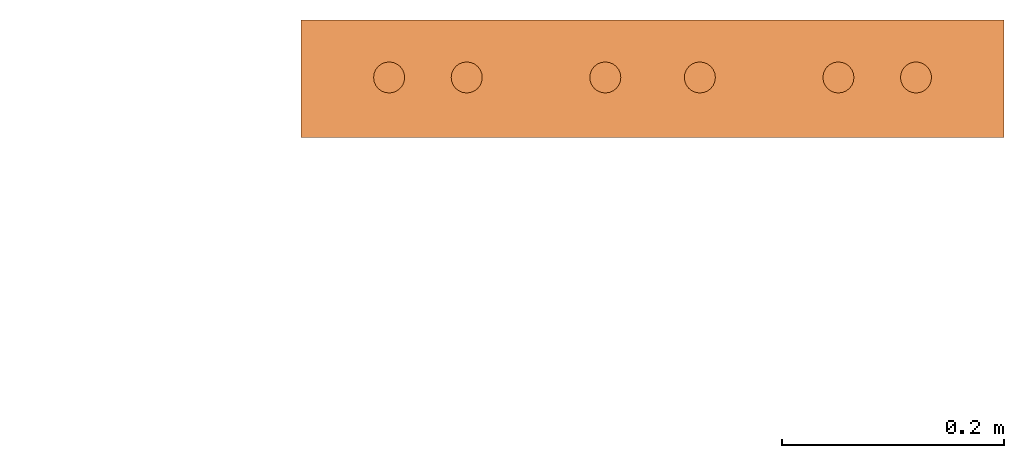
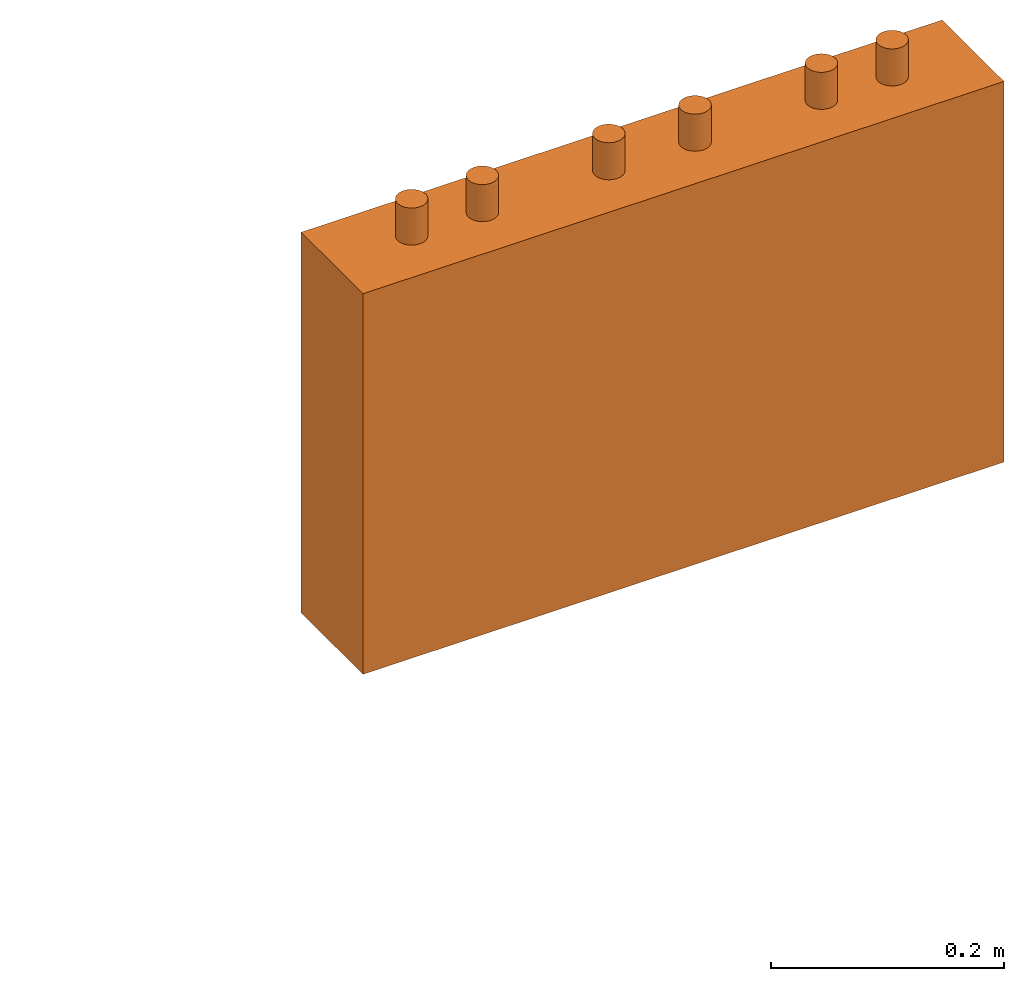
# One storey, part 4 of 5: 1 proxy.
"""IFC2X3 building model written with IfcOpenShell, lengths in millimetres."""

from ifc_helpers import new_model, entity, si_unit, converted_unit, derived_unit, direction, frame, origin, place, context, subcontext, project, spatial, faceted_brep, source, transform, mapped, material, material_list, type_object, type_shapes, element, save


model = new_model("IFC2X3")

# Units and contexts
model_context = context("Model", 3, precision=0.01, world=origin(), true_north=direction((6.12303176911189e-17, 1.0)))
body_context = subcontext(model_context, "Body", "Model", "MODEL_VIEW")
ifc_project = project(units=[si_unit("LENGTHUNIT", "METRE", prefix="MILLI"), si_unit("AREAUNIT", "SQUARE_METRE"), si_unit("VOLUMEUNIT", "CUBIC_METRE"), converted_unit("PLANEANGLEUNIT", "DEGREE", entity("IfcRatioMeasure", 0.0174532925199433), si_unit("PLANEANGLEUNIT", "RADIAN"), dimensions=[0, 0, 0, 0, 0, 0, 0]), si_unit("MASSUNIT", "GRAM", prefix="KILO"), derived_unit("MASSDENSITYUNIT", [(si_unit("MASSUNIT", "GRAM", prefix="KILO"), 1), (si_unit("LENGTHUNIT", "METRE"), -3)]), derived_unit("MOMENTOFINERTIAUNIT", [(si_unit("LENGTHUNIT", "METRE"), 4)]), si_unit("TIMEUNIT", "SECOND"), si_unit("FREQUENCYUNIT", "HERTZ"), si_unit("THERMODYNAMICTEMPERATUREUNIT", "DEGREE_CELSIUS"), derived_unit("THERMALTRANSMITTANCEUNIT", [(si_unit("MASSUNIT", "GRAM", prefix="KILO"), 1), (si_unit("THERMODYNAMICTEMPERATUREUNIT", "KELVIN"), -1), (si_unit("TIMEUNIT", "SECOND"), -3)]), derived_unit("VOLUMETRICFLOWRATEUNIT", [(si_unit("LENGTHUNIT", "METRE"), 3), (si_unit("TIMEUNIT", "SECOND"), -1)]), derived_unit("MASSFLOWRATEUNIT", [(si_unit("MASSUNIT", "GRAM", prefix="KILO"), 1), (si_unit("TIMEUNIT", "SECOND"), -1)]), derived_unit("ROTATIONALFREQUENCYUNIT", [(si_unit("TIMEUNIT", "SECOND"), -1)]), si_unit("ELECTRICCURRENTUNIT", "AMPERE"), si_unit("ELECTRICVOLTAGEUNIT", "VOLT"), si_unit("POWERUNIT", "WATT"), si_unit("FORCEUNIT", "NEWTON", prefix="KILO"), si_unit("ILLUMINANCEUNIT", "LUX"), si_unit("LUMINOUSFLUXUNIT", "LUMEN"), si_unit("LUMINOUSINTENSITYUNIT", "CANDELA"), derived_unit("USERDEFINED", [(si_unit("MASSUNIT", "GRAM", prefix="KILO"), -1), (si_unit("LENGTHUNIT", "METRE"), -2), (si_unit("TIMEUNIT", "SECOND"), 3), (si_unit("LUMINOUSFLUXUNIT", "LUMEN"), 1)]), derived_unit("LINEARVELOCITYUNIT", [(si_unit("LENGTHUNIT", "METRE"), 1), (si_unit("TIMEUNIT", "SECOND"), -1)]), si_unit("PRESSUREUNIT", "PASCAL"), derived_unit("USERDEFINED", [(si_unit("LENGTHUNIT", "METRE"), -2), (si_unit("MASSUNIT", "GRAM", prefix="KILO"), 1), (si_unit("TIMEUNIT", "SECOND"), -2)]), derived_unit("LINEARFORCEUNIT", [(si_unit("MASSUNIT", "GRAM", prefix="KILO"), 1), (si_unit("LENGTHUNIT", "METRE"), 1), (si_unit("TIMEUNIT", "SECOND"), -2), (si_unit("LENGTHUNIT", "METRE"), -1)]), derived_unit("PLANARFORCEUNIT", [(si_unit("MASSUNIT", "GRAM", prefix="KILO"), 1), (si_unit("LENGTHUNIT", "METRE"), 1), (si_unit("TIMEUNIT", "SECOND"), -2), (si_unit("LENGTHUNIT", "METRE"), -2)])], contexts=[model_context])

# Site, building, storey
site_placement = place(None, frame((0.0, 2493.83037508239, 0.0)))
site = spatial("IfcSite", under=ifc_project, at=site_placement, CompositionType="ELEMENT")
building_placement = place(site_placement, origin())
building = spatial("IfcBuilding", under=site, at=building_placement, CompositionType="ELEMENT")
storey_placement = place(building_placement, frame((0.0, 0.0, 19800.0)))
storey = spatial("IfcBuildingStorey", under=building, at=storey_placement, Name="06", CompositionType="ELEMENT", Elevation=19800.0)

# Proxy
ifc_material_1 = material()
ifc_material_2 = material()
ifc_material_list = material_list([ifc_material_1, ifc_material_2])
building_element_proxy_type = type_object("IfcBuildingElementProxyType", PredefinedType="NOTDEFINED", material=ifc_material_1)
shared_shape = source(origin(), body_context, "Body", "Brep", [
    faceted_brep([(61.7366777047886, 89.258069163288, 398.0), (63.9615384211591, 86.3585742266764, 398.0), (65.3601443362239, 82.9820408581116, 398.0), (65.837182768177, 79.3585742266763, 398.0), (65.3601443362239, 75.735107595241, 398.0), (63.9615384211591, 72.3585742266763, 398.0), (61.7366777047886, 69.4590792900646, 398.0), (58.8371827681769, 67.2342185736942, 398.0), (55.4606493996122, 65.8356126586294, 398.0), (51.8371827681769, 65.3585742266764, 398.0), (48.2137161367416, 65.8356126586295, 398.0), (44.8371827681769, 67.2342185736943, 398.0), (41.9376878315653, 69.4590792900647, 398.0), (39.7128271151948, 72.3585742266764, 398.0), (38.31422120013, 75.7351075952411, 398.0), (37.837182768177, 79.3585742266764, 398.0), (38.31422120013, 82.9820408581117, 398.0), (39.7128271151949, 86.3585742266764, 398.0), (41.9376878315653, 89.258069163288, 398.0), (44.837182768177, 91.4829298796585, 398.0), (48.2137161367417, 92.8815357947233, 398.0), (51.837182768177, 93.3585742266764, 398.0), (55.4606493996123, 92.8815357947233, 398.0), (58.837182768177, 91.4829298796585, 398.0), (58.8371827681769, 67.2342185736942, 436.716690815491), (61.7366777047886, 69.4590792900646, 436.716690815491), (63.9615384211591, 72.3585742266763, 436.716690815491), (65.3601443362239, 75.735107595241, 436.716690815491), (65.837182768177, 79.3585742266764, 436.716690815491), (65.3601443362239, 82.9820408581116, 436.716690815491), (63.9615384211591, 86.3585742266764, 436.716690815491), (61.7366777047886, 89.258069163288, 436.716690815491), (58.837182768177, 91.4829298796585, 436.716690815491), (55.4606493996123, 92.8815357947233, 436.716690815491), (51.837182768177, 93.3585742266764, 436.716690815491), (48.2137161367417, 92.8815357947233, 436.716690815491), (44.837182768177, 91.4829298796585, 436.716690815491), (41.9376878315653, 89.258069163288, 436.716690815491), (39.7128271151949, 86.3585742266764, 436.716690815491), (38.31422120013, 82.9820408581117, 436.716690815491), (37.837182768177, 79.3585742266764, 436.716690815491), (38.31422120013, 75.7351075952411, 436.716690815491), (39.7128271151948, 72.3585742266764, 436.716690815491), (41.9376878315653, 69.4590792900647, 436.716690815491), (44.8371827681769, 67.2342185736943, 436.716690815491), (48.2137161367416, 65.8356126586295, 436.716690815491), (51.8371827681769, 65.3585742266764, 436.716690815491), (55.4606493996122, 65.8356126586294, 436.716690815491)], [[[0, 1, 2, 3, 4, 5, 6, 7, 8, 9, 10, 11, 12, 13, 14, 15, 16, 17, 18, 19, 20, 21, 22, 23]], [[24, 25, 26, 27, 28, 29, 30, 31, 32, 33, 34, 35, 36, 37, 38, 39, 40, 41, 42, 43, 44, 45, 46, 47]], [[40, 15, 14, 41]], [[13, 42, 41, 14]], [[43, 12, 11, 44]], [[13, 12, 43, 42]], [[44, 11, 10, 45]], [[9, 46, 45, 10]], [[47, 8, 7, 24]], [[6, 25, 24, 7]], [[26, 5, 4, 27]], [[6, 5, 26, 25]], [[27, 4, 3, 28]], [[47, 46, 9, 8]], [[1, 30, 29, 2]], [[0, 31, 30, 1]], [[22, 33, 32, 23]], [[23, 32, 31, 0]], [[21, 34, 33, 22]], [[28, 3, 2, 29]], [[35, 20, 19, 36]], [[18, 37, 36, 19]], [[38, 17, 16, 39]], [[18, 17, 38, 37]], [[39, 16, 15, 40]], [[35, 34, 21, 20]]]),
    faceted_brep([(58.837182768177, 542.517070120343, 436.716690815491), (61.7366777047886, 544.741930836713, 436.716690815491), (63.9615384211591, 547.641425773325, 436.716690815491), (65.360144336224, 551.017959141889, 436.716690815491), (65.837182768177, 554.641425773325, 436.716690815491), (65.360144336224, 558.26489240476, 436.716690815491), (63.9615384211592, 561.641425773325, 436.716690815491), (61.7366777047887, 564.540920709937, 436.716690815491), (58.8371827681771, 566.765781426307, 436.716690815491), (55.4606493996123, 568.164387341372, 436.716690815491), (51.8371827681771, 568.641425773325, 436.716690815491), (48.2137161367418, 568.164387341372, 436.716690815491), (44.8371827681771, 566.765781426307, 436.716690815491), (41.9376878315654, 564.540920709937, 436.716690815491), (39.7128271151949, 561.641425773325, 436.716690815491), (38.3142212001301, 558.26489240476, 436.716690815491), (37.837182768177, 554.641425773325, 436.716690815491), (38.3142212001301, 551.01795914189, 436.716690815491), (39.7128271151949, 547.641425773325, 436.716690815491), (41.9376878315653, 544.741930836713, 436.716690815491), (44.837182768177, 542.517070120343, 436.716690815491), (48.2137161367417, 541.118464205278, 436.716690815491), (51.837182768177, 540.641425773325, 436.716690815491), (55.4606493996123, 541.118464205278, 436.716690815491), (51.8371827681771, 568.641425773325, 398.0), (55.4606493996123, 568.164387341372, 398.0), (58.8371827681771, 566.765781426307, 398.0), (61.7366777047887, 564.540920709937, 398.0), (63.9615384211592, 561.641425773325, 398.0), (65.360144336224, 558.26489240476, 398.0), (65.837182768177, 554.641425773325, 398.0), (65.360144336224, 551.017959141889, 398.0), (63.9615384211591, 547.641425773325, 398.0), (61.7366777047886, 544.741930836713, 398.0), (58.837182768177, 542.517070120343, 398.0), (55.4606493996123, 541.118464205278, 398.0), (51.837182768177, 540.641425773325, 398.0), (48.2137161367417, 541.118464205278, 398.0), (44.837182768177, 542.517070120343, 398.0), (41.9376878315653, 544.741930836713, 398.0), (39.7128271151949, 547.641425773325, 398.0), (38.3142212001301, 551.01795914189, 398.0), (37.837182768177, 554.641425773325, 398.0), (38.3142212001301, 558.26489240476, 398.0), (39.7128271151949, 561.641425773325, 398.0), (41.9376878315654, 564.540920709937, 398.0), (44.8371827681771, 566.765781426307, 398.0), (48.2137161367418, 568.164387341372, 398.0)], [[[0, 1, 2, 3, 4, 5, 6, 7, 8, 9, 10, 11, 12, 13, 14, 15, 16, 17, 18, 19, 20, 21, 22, 23]], [[24, 25, 26, 27, 28, 29, 30, 31, 32, 33, 34, 35, 36, 37, 38, 39, 40, 41, 42, 43, 44, 45, 46, 47]], [[17, 41, 40, 18]], [[39, 19, 18, 40]], [[20, 38, 37, 21]], [[39, 38, 20, 19]], [[21, 37, 36, 22]], [[41, 17, 16, 42]], [[23, 35, 34, 0]], [[33, 1, 0, 34]], [[2, 32, 31, 3]], [[33, 32, 2, 1]], [[3, 31, 30, 4]], [[35, 23, 22, 36]], [[29, 5, 4, 30]], [[28, 6, 5, 29]], [[9, 25, 24, 10]], [[27, 7, 6, 28]], [[26, 8, 7, 27]], [[26, 25, 9, 8]], [[11, 47, 46, 12]], [[45, 13, 12, 46]], [[14, 44, 43, 15]], [[45, 44, 14, 13]], [[15, 43, 42, 16]], [[47, 11, 10, 24]]]),
    faceted_brep([(58.8371827681769, 472.517070120343, 436.716690815491), (61.7366777047886, 474.741930836713, 436.716690815491), (63.961538421159, 477.641425773325, 436.716690815491), (65.3601443362239, 481.017959141889, 436.716690815491), (65.8371827681769, 484.641425773325, 436.716690815491), (65.3601443362239, 488.26489240476, 436.716690815491), (63.9615384211591, 491.641425773325, 436.716690815491), (61.7366777047886, 494.540920709936, 436.716690815491), (58.837182768177, 496.765781426307, 436.716690815491), (55.4606493996123, 498.164387341372, 436.716690815491), (51.837182768177, 498.641425773325, 436.716690815491), (48.2137161367417, 498.164387341372, 436.716690815491), (44.837182768177, 496.765781426307, 436.716690815491), (41.9376878315653, 494.540920709937, 436.716690815491), (39.7128271151948, 491.641425773325, 436.716690815491), (38.31422120013, 488.26489240476, 436.716690815491), (37.837182768177, 484.641425773325, 436.716690815491), (38.31422120013, 481.01795914189, 436.716690815491), (39.7128271151948, 477.641425773325, 436.716690815491), (41.9376878315653, 474.741930836713, 436.716690815491), (44.8371827681769, 472.517070120343, 436.716690815491), (48.2137161367416, 471.118464205278, 436.716690815491), (51.8371827681769, 470.641425773325, 436.716690815491), (55.4606493996122, 471.118464205278, 436.716690815491), (51.837182768177, 498.641425773325, 398.0), (55.4606493996123, 498.164387341372, 398.0), (58.837182768177, 496.765781426307, 398.0), (61.7366777047886, 494.540920709936, 398.0), (63.9615384211591, 491.641425773325, 398.0), (65.3601443362239, 488.26489240476, 398.0), (65.8371827681769, 484.641425773325, 398.0), (65.3601443362239, 481.017959141889, 398.0), (63.961538421159, 477.641425773325, 398.0), (61.7366777047886, 474.741930836713, 398.0), (58.8371827681769, 472.517070120343, 398.0), (55.4606493996122, 471.118464205278, 398.0), (51.8371827681769, 470.641425773325, 398.0), (48.2137161367416, 471.118464205278, 398.0), (44.8371827681769, 472.517070120343, 398.0), (41.9376878315653, 474.741930836713, 398.0), (39.7128271151948, 477.641425773325, 398.0), (38.31422120013, 481.01795914189, 398.0), (37.837182768177, 484.641425773325, 398.0), (38.31422120013, 488.26489240476, 398.0), (39.7128271151948, 491.641425773325, 398.0), (41.9376878315653, 494.540920709937, 398.0), (44.837182768177, 496.765781426307, 398.0), (48.2137161367417, 498.164387341372, 398.0)], [[[0, 1, 2, 3, 4, 5, 6, 7, 8, 9, 10, 11, 12, 13, 14, 15, 16, 17, 18, 19, 20, 21, 22, 23]], [[24, 25, 26, 27, 28, 29, 30, 31, 32, 33, 34, 35, 36, 37, 38, 39, 40, 41, 42, 43, 44, 45, 46, 47]], [[16, 42, 41, 17]], [[40, 18, 17, 41]], [[19, 39, 38, 20]], [[40, 39, 19, 18]], [[20, 38, 37, 21]], [[36, 22, 21, 37]], [[23, 35, 34, 0]], [[33, 1, 0, 34]], [[2, 32, 31, 3]], [[33, 32, 2, 1]], [[3, 31, 30, 4]], [[23, 22, 36, 35]], [[28, 6, 5, 29]], [[27, 7, 6, 28]], [[25, 9, 8, 26]], [[26, 8, 7, 27]], [[24, 10, 9, 25]], [[4, 30, 29, 5]], [[11, 47, 46, 12]], [[45, 13, 12, 46]], [[14, 44, 43, 15]], [[45, 44, 14, 13]], [[15, 43, 42, 16]], [[11, 10, 24, 47]]]),
    faceted_brep([(58.8371827681766, 347.517070120343, 436.716690815491), (61.7366777047883, 349.741930836713, 436.716690815491), (63.9615384211588, 352.641425773325, 436.716690815491), (65.3601443362236, 356.017959141889, 436.716690815491), (65.8371827681767, 359.641425773325, 436.716690815491), (65.3601443362237, 363.26489240476, 436.716690815491), (63.9615384211589, 366.641425773325, 436.716690815491), (61.7366777047884, 369.540920709937, 436.716690815491), (58.8371827681767, 371.765781426307, 436.716690815491), (55.460649399612, 373.164387341372, 436.716690815491), (51.8371827681767, 373.641425773325, 436.716690815491), (48.2137161367414, 373.164387341372, 436.716690815491), (44.8371827681767, 371.765781426307, 436.716690815491), (41.9376878315651, 369.540920709937, 436.716690815491), (39.7128271151946, 366.641425773325, 436.716690815491), (38.3142212001298, 363.26489240476, 436.716690815491), (37.8371827681767, 359.641425773325, 436.716690815491), (38.3142212001298, 356.01795914189, 436.716690815491), (39.7128271151945, 352.641425773325, 436.716690815491), (41.937687831565, 349.741930836713, 436.716690815491), (44.8371827681767, 347.517070120343, 436.716690815491), (48.2137161367414, 346.118464205278, 436.716690815491), (51.8371827681766, 345.641425773325, 436.716690815491), (55.4606493996119, 346.118464205278, 436.716690815491), (51.8371827681767, 373.641425773325, 398.0), (55.460649399612, 373.164387341372, 398.0), (58.8371827681767, 371.765781426307, 398.0), (61.7366777047884, 369.540920709937, 398.0), (63.9615384211589, 366.641425773325, 398.0), (65.3601443362237, 363.26489240476, 398.0), (65.8371827681767, 359.641425773325, 398.0), (65.3601443362236, 356.017959141889, 398.0), (63.9615384211588, 352.641425773325, 398.0), (61.7366777047883, 349.741930836713, 398.0), (58.8371827681766, 347.517070120343, 398.0), (55.4606493996119, 346.118464205278, 398.0), (51.8371827681766, 345.641425773325, 398.0), (48.2137161367414, 346.118464205278, 398.0), (44.8371827681767, 347.517070120343, 398.0), (41.937687831565, 349.741930836713, 398.0), (39.7128271151945, 352.641425773325, 398.0), (38.3142212001298, 356.01795914189, 398.0), (37.8371827681767, 359.641425773325, 398.0), (38.3142212001298, 363.26489240476, 398.0), (39.7128271151946, 366.641425773325, 398.0), (41.9376878315651, 369.540920709937, 398.0), (44.8371827681767, 371.765781426307, 398.0), (48.2137161367414, 373.164387341372, 398.0)], [[[0, 1, 2, 3, 4, 5, 6, 7, 8, 9, 10, 11, 12, 13, 14, 15, 16, 17, 18, 19, 20, 21, 22, 23]], [[24, 25, 26, 27, 28, 29, 30, 31, 32, 33, 34, 35, 36, 37, 38, 39, 40, 41, 42, 43, 44, 45, 46, 47]], [[16, 42, 41, 17]], [[40, 18, 17, 41]], [[19, 39, 38, 20]], [[40, 39, 19, 18]], [[20, 38, 37, 21]], [[36, 22, 21, 37]], [[23, 35, 34, 0]], [[33, 1, 0, 34]], [[2, 32, 31, 3]], [[33, 32, 2, 1]], [[3, 31, 30, 4]], [[23, 22, 36, 35]], [[28, 6, 5, 29]], [[27, 7, 6, 28]], [[25, 9, 8, 26]], [[26, 8, 7, 27]], [[24, 10, 9, 25]], [[4, 30, 29, 5]], [[11, 47, 46, 12]], [[45, 13, 12, 46]], [[14, 44, 43, 15]], [[45, 44, 14, 13]], [[15, 43, 42, 16]], [[11, 10, 24, 47]]]),
    faceted_brep([(58.8371827681766, 262.234218573694, 436.716690815491), (61.7366777047883, 264.459079290065, 436.716690815491), (63.9615384211588, 267.358574226676, 436.716690815491), (65.3601443362236, 270.735107595241, 436.716690815491), (65.8371827681767, 274.358574226676, 436.716690815491), (65.3601443362237, 277.982040858112, 436.716690815491), (63.9615384211588, 281.358574226676, 436.716690815491), (61.7366777047884, 284.258069163288, 436.716690815491), (58.8371827681767, 286.482929879658, 436.716690815491), (55.460649399612, 287.881535794723, 436.716690815491), (51.8371827681767, 288.358574226676, 436.716690815491), (48.2137161367414, 287.881535794723, 436.716690815491), (44.8371827681767, 286.482929879659, 436.716690815491), (41.9376878315651, 284.258069163288, 436.716690815491), (39.7128271151946, 281.358574226676, 436.716690815491), (38.3142212001298, 277.982040858112, 436.716690815491), (37.8371827681767, 274.358574226676, 436.716690815491), (38.3142212001297, 270.735107595241, 436.716690815491), (39.7128271151945, 267.358574226676, 436.716690815491), (41.937687831565, 264.459079290065, 436.716690815491), (44.8371827681767, 262.234218573694, 436.716690815491), (48.2137161367414, 260.835612658629, 436.716690815491), (51.8371827681766, 260.358574226676, 436.716690815491), (55.4606493996119, 260.835612658629, 436.716690815491), (51.8371827681767, 288.358574226676, 398.0), (55.460649399612, 287.881535794723, 398.0), (58.8371827681767, 286.482929879658, 398.0), (61.7366777047884, 284.258069163288, 398.0), (63.9615384211588, 281.358574226676, 398.0), (65.3601443362237, 277.982040858112, 398.0), (65.8371827681767, 274.358574226676, 398.0), (65.3601443362236, 270.735107595241, 398.0), (63.9615384211588, 267.358574226676, 398.0), (61.7366777047883, 264.459079290065, 398.0), (58.8371827681766, 262.234218573694, 398.0), (55.4606493996119, 260.835612658629, 398.0), (51.8371827681766, 260.358574226676, 398.0), (48.2137161367414, 260.835612658629, 398.0), (44.8371827681767, 262.234218573694, 398.0), (41.937687831565, 264.459079290065, 398.0), (39.7128271151945, 267.358574226676, 398.0), (38.3142212001297, 270.735107595241, 398.0), (37.8371827681767, 274.358574226676, 398.0), (38.3142212001298, 277.982040858112, 398.0), (39.7128271151946, 281.358574226676, 398.0), (41.9376878315651, 284.258069163288, 398.0), (44.8371827681767, 286.482929879659, 398.0), (48.2137161367414, 287.881535794723, 398.0)], [[[0, 1, 2, 3, 4, 5, 6, 7, 8, 9, 10, 11, 12, 13, 14, 15, 16, 17, 18, 19, 20, 21, 22, 23]], [[24, 25, 26, 27, 28, 29, 30, 31, 32, 33, 34, 35, 36, 37, 38, 39, 40, 41, 42, 43, 44, 45, 46, 47]], [[16, 42, 41, 17]], [[40, 18, 17, 41]], [[19, 39, 38, 20]], [[40, 39, 19, 18]], [[20, 38, 37, 21]], [[36, 22, 21, 37]], [[23, 35, 34, 0]], [[33, 1, 0, 34]], [[2, 32, 31, 3]], [[33, 32, 2, 1]], [[3, 31, 30, 4]], [[23, 22, 36, 35]], [[4, 30, 29, 5]], [[28, 6, 5, 29]], [[7, 27, 26, 8]], [[28, 27, 7, 6]], [[8, 26, 25, 9]], [[24, 10, 9, 25]], [[11, 47, 46, 12]], [[45, 13, 12, 46]], [[14, 44, 43, 15]], [[45, 44, 14, 13]], [[15, 43, 42, 16]], [[11, 10, 24, 47]]]),
    faceted_brep([(58.8371827681768, 137.234218573694, 436.716690815491), (61.7366777047885, 139.459079290065, 436.716690815491), (63.961538421159, 142.358574226676, 436.716690815491), (65.3601443362238, 145.735107595241, 436.716690815491), (65.8371827681769, 149.358574226676, 436.716690815491), (65.3601443362239, 152.982040858112, 436.716690815491), (63.961538421159, 156.358574226676, 436.716690815491), (61.7366777047886, 159.258069163288, 436.716690815491), (58.8371827681769, 161.482929879659, 436.716690815491), (55.4606493996122, 162.881535794723, 436.716690815491), (51.8371827681769, 163.358574226676, 436.716690815491), (48.2137161367416, 162.881535794723, 436.716690815491), (44.8371827681769, 161.482929879659, 436.716690815491), (41.9376878315653, 159.258069163288, 436.716690815491), (39.7128271151948, 156.358574226676, 436.716690815491), (38.31422120013, 152.982040858112, 436.716690815491), (37.8371827681769, 149.358574226676, 436.716690815491), (38.3142212001299, 145.735107595241, 436.716690815491), (39.7128271151947, 142.358574226676, 436.716690815491), (41.9376878315652, 139.459079290065, 436.716690815491), (44.8371827681769, 137.234218573694, 436.716690815491), (48.2137161367416, 135.83561265863, 436.716690815491), (51.8371827681768, 135.358574226676, 436.716690815491), (55.4606493996121, 135.835612658629, 436.716690815491), (61.7366777047886, 159.258069163288, 398.0), (63.961538421159, 156.358574226676, 398.0), (65.3601443362239, 152.982040858112, 398.0), (65.8371827681769, 149.358574226676, 398.0), (65.3601443362238, 145.735107595241, 398.0), (63.961538421159, 142.358574226676, 398.0), (61.7366777047885, 139.459079290065, 398.0), (58.8371827681768, 137.234218573694, 398.0), (55.4606493996121, 135.835612658629, 398.0), (51.8371827681768, 135.358574226676, 398.0), (48.2137161367416, 135.83561265863, 398.0), (44.8371827681769, 137.234218573694, 398.0), (41.9376878315652, 139.459079290065, 398.0), (39.7128271151947, 142.358574226676, 398.0), (38.3142212001299, 145.735107595241, 398.0), (37.8371827681769, 149.358574226676, 398.0), (38.31422120013, 152.982040858112, 398.0), (39.7128271151948, 156.358574226676, 398.0), (41.9376878315653, 159.258069163288, 398.0), (44.8371827681769, 161.482929879659, 398.0), (48.2137161367416, 162.881535794723, 398.0), (51.8371827681769, 163.358574226676, 398.0), (55.4606493996122, 162.881535794723, 398.0), (58.8371827681769, 161.482929879659, 398.0)], [[[0, 1, 2, 3, 4, 5, 6, 7, 8, 9, 10, 11, 12, 13, 14, 15, 16, 17, 18, 19, 20, 21, 22, 23]], [[24, 25, 26, 27, 28, 29, 30, 31, 32, 33, 34, 35, 36, 37, 38, 39, 40, 41, 42, 43, 44, 45, 46, 47]], [[16, 39, 38, 17]], [[37, 18, 17, 38]], [[19, 36, 35, 20]], [[37, 36, 19, 18]], [[20, 35, 34, 21]], [[33, 22, 21, 34]], [[23, 32, 31, 0]], [[30, 1, 0, 31]], [[2, 29, 28, 3]], [[30, 29, 2, 1]], [[3, 28, 27, 4]], [[23, 22, 33, 32]], [[25, 6, 5, 26]], [[24, 7, 6, 25]], [[46, 9, 8, 47]], [[47, 8, 7, 24]], [[45, 10, 9, 46]], [[4, 27, 26, 5]], [[11, 44, 43, 12]], [[42, 13, 12, 43]], [[14, 41, 40, 15]], [[42, 41, 14, 13]], [[15, 40, 39, 16]], [[11, 10, 45, 44]]]),
    faceted_brep([(106.0, 0.0, 0.0), (106.0, 634.0, 0.0), (106.0, 634.0, 398.0), (106.0, 0.0, 398.0), (0.0, 634.0, 398.0), (0.0, 524.500000000001, 254.822902819641), (0.0, 518.470476127564, 257.320413382257), (0.0, 529.677669529664, 250.849937254693), (0.0, 512.0, 258.17226772503), (0.0, 122.0, 258.17226772503), (0.0, 533.650635094612, 245.672267725029), (0.0, 536.148145657227, 239.642743852593), (0.0, 537.0, 233.17226772503), (0.0, 634.0, 0.0), (0.0, 0.0, 398.0), (0.0, 537.0, 143.17226772503), (0.0, 536.148145657227, 136.701791597467), (0.0, 533.650635094611, 130.67226772503), (0.0, 529.677669529664, 125.494598195366), (0.0, 524.5, 121.521632630419), (0.0, 518.470476127563, 119.024122067803), (0.0, 512.0, 118.17226772503), (0.0, 122.0, 118.172267725031), (0.0, 0.0, 0.0), (0.0, 97.0, 233.17226772503), (0.0, 115.529523872437, 119.024122067805), (0.0, 109.5, 121.521632630421), (0.0, 104.322330470337, 125.494598195368), (0.0, 100.349364905389, 130.672267725032), (0.0, 97.8518543427736, 136.701791597469), (0.0, 97.0, 143.172267725033), (0.0, 97.8518543427739, 239.642743852593), (0.0, 115.529523872438, 257.320413382257), (0.0, 109.500000000001, 254.822902819641), (0.0, 104.322330470337, 250.849937254693), (0.0, 100.34936490539, 245.67226772503), (16.2395209800454, 533.650635094612, 245.672267725029), (16.2395209800454, 536.148145657227, 239.642743852593), (16.2395209800454, 537.0, 233.17226772503), (16.2395209800454, 537.0, 143.17226772503), (16.2395209800454, 536.148145657227, 136.701791597467), (16.2395209800454, 533.650635094611, 130.67226772503), (16.2395209800454, 529.677669529664, 125.494598195366), (16.2395209800454, 524.5, 121.521632630419), (16.2395209800454, 518.470476127563, 119.024122067803), (16.2395209800454, 512.0, 118.17226772503), (16.2395209800454, 122.0, 118.172267725032), (16.2395209800454, 115.529523872437, 119.024122067805), (16.2395209800454, 109.5, 121.521632630421), (16.2395209800454, 104.322330470337, 125.494598195368), (16.2395209800454, 100.349364905389, 130.672267725032), (16.2395209800454, 97.8518543427736, 136.701791597469), (16.2395209800454, 97.0, 143.172267725032), (16.2395209800454, 97.0, 233.17226772503), (16.2395209800454, 97.8518543427739, 239.642743852593), (16.2395209800454, 100.34936490539, 245.67226772503), (16.2395209800454, 104.322330470337, 250.849937254694), (16.2395209800454, 109.500000000001, 254.822902819641), (16.2395209800454, 115.529523872438, 257.320413382257), (16.2395209800454, 122.0, 258.17226772503), (16.2395209800454, 512.0, 258.17226772503), (16.2395209800454, 518.470476127564, 257.320413382257), (16.2395209800454, 524.500000000001, 254.822902819641), (16.2395209800454, 529.677669529664, 250.849937254693)], [[[0, 1, 2, 3]], [[4, 5, 6]], [[5, 4, 7]], [[6, 8, 4]], [[4, 8, 9]], [[10, 7, 4]], [[11, 10, 4]], [[12, 11, 4]], [[4, 13, 12]], [[9, 14, 4]], [[15, 12, 13]], [[16, 15, 13]], [[16, 13, 17]], [[18, 17, 13]], [[13, 19, 18]], [[19, 13, 20]], [[21, 20, 13]], [[13, 22, 21]], [[22, 13, 23]], [[14, 24, 23]], [[25, 22, 23]], [[23, 26, 25]], [[26, 23, 27]], [[28, 27, 23]], [[28, 23, 29]], [[30, 29, 23]], [[30, 23, 24]], [[31, 24, 14]], [[9, 32, 14]], [[33, 14, 32]], [[14, 33, 34]], [[34, 35, 14]], [[35, 31, 14]], [[2, 1, 13, 4]], [[3, 2, 4, 14]], [[0, 3, 14, 23]], [[1, 0, 23, 13]], [[36, 37, 38, 39, 40, 41, 42, 43, 44, 45, 46, 47, 48, 49, 50, 51, 52, 53, 54, 55, 56, 57, 58, 59, 60, 61, 62, 63]], [[9, 8, 60, 59]], [[32, 9, 59, 58]], [[33, 32, 58, 57]], [[33, 57, 56, 34]], [[35, 34, 56, 55]], [[31, 35, 55, 54]], [[31, 54, 53, 24]], [[24, 53, 52, 30]], [[29, 30, 52, 51]], [[28, 29, 51, 50]], [[28, 50, 49, 27]], [[26, 27, 49, 48]], [[25, 26, 48, 47]], [[25, 47, 46, 22]], [[22, 46, 45, 21]], [[20, 21, 45, 44]], [[19, 20, 44, 43]], [[19, 43, 42, 18]], [[17, 18, 42, 41]], [[16, 17, 41, 40]], [[16, 40, 39, 15]], [[15, 39, 38, 12]], [[11, 12, 38, 37]], [[10, 11, 37, 36]], [[10, 36, 63, 7]], [[5, 7, 63, 62]], [[6, 5, 62, 61]], [[6, 61, 60, 8]]]),
])
type_shapes(building_element_proxy_type, [shared_shape])
proxy_placement = place(storey_placement, frame((66893.1118832777, 5906.16966279016, 950.0), z_axis=(0.0, 0.0, 1.0), x_axis=(0.0, -1.0, 0.0)))
element("IfcBuildingElementProxy", 1, at=proxy_placement, inside=storey, type_object=building_element_proxy_type, material=ifc_material_list, context=body_context, shape_type="MappedRepresentation", body=[
    mapped(shared_shape, transform((0.0, 0.0, 0.0), scale=1.0)),
])

save(model, "model.ifc")
